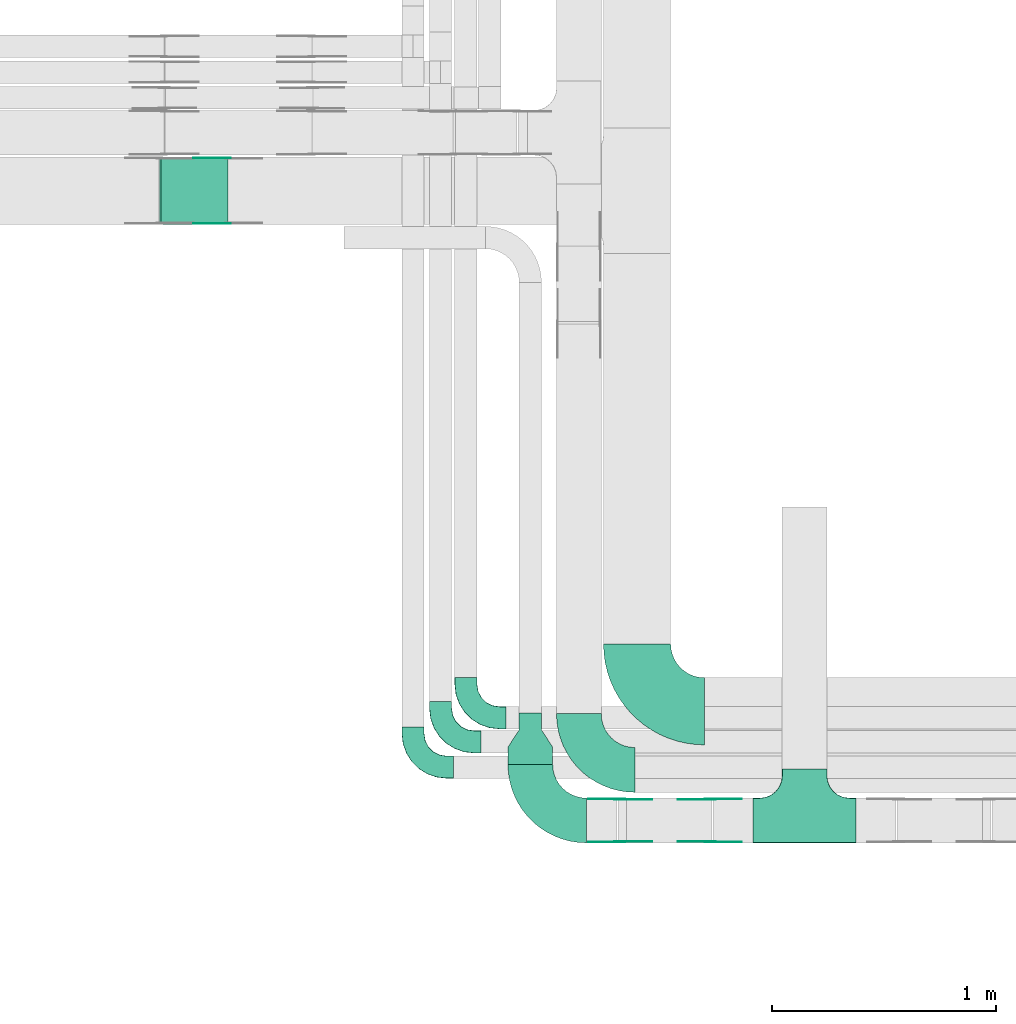
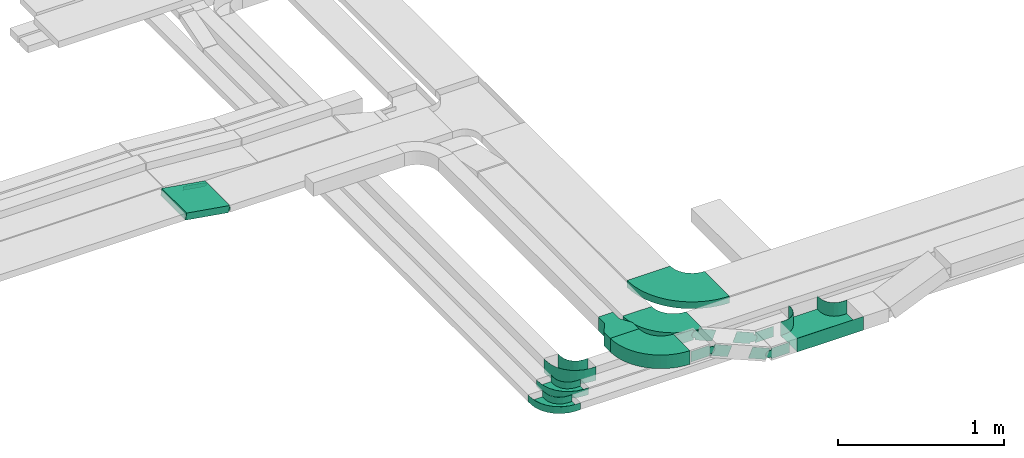
# One storey, part 3 of 19: 18 flow fittings, 1 flow segment.
"""IFC2X3 building model written with IfcOpenShell, lengths in millimetres."""

import ifcopenshell
import ifcopenshell.guid

model = None  # the IFC model being written
_history = None  # IfcOwnerHistory: only IFC2X3 demands one
_inside = {}  # id of a spatial element -> (the spatial element, [elements in it])
_under = {}  # id of a project, library or spatial element -> (it, [spatial elements below it])
_declared = {}  # id of a project -> (the project, [libraries it declares])
_typed = {}  # id of a type object -> (the type object, [elements of that type])
_made_of = {}  # id of a material, layer set ... -> (it, [elements and type objects made of it])


def new_model(schema):
    """Start an empty IFC model of exactly this schema.

    Asked for "IFC4X3", IfcOpenShell would pick the latest addendum, in which some entities
    have other attributes; the version numbers below select the first issue.
    IFC2X3 requires an IfcOwnerHistory on every rooted entity: one is made here for all.
    """
    global model, _history
    if schema == "IFC4X3":
        model = ifcopenshell.file(schema_version=(4, 3, 0, 0))
    else:
        model = ifcopenshell.file(schema=schema)
    _inside.clear()
    _under.clear()
    _declared.clear()
    _typed.clear()
    _made_of.clear()
    _history = None
    if model.schema == "IFC2X3":
        org = make("IfcOrganization", Name="unknown")
        user = make(
            "IfcPersonAndOrganization",
            ThePerson=make("IfcPerson", FamilyName="unknown"),
            TheOrganization=org,
        )
        app = make(
            "IfcApplication",
            ApplicationDeveloper=org,
            Version="unknown",
            ApplicationFullName="unknown",
            ApplicationIdentifier="unknown",
        )
        _history = make(
            "IfcOwnerHistory",
            OwningUser=user,
            OwningApplication=app,
            ChangeAction="ADDED",
            CreationDate=0,
        )
    return model


def make(cls, **values):
    """One entity of the class cls with the attributes given. An attribute that is None is left unset."""
    return model.create_entity(
        cls, **{name: value for name, value in values.items() if value is not None}
    )


def entity(cls, *values):
    """Any entity or typed value of the class cls, its attributes in the order of the schema. None: left unset."""
    e = model.create_entity(cls)
    for i, value in enumerate(values):
        if value is not None:
            e[i] = value
    return e


def rooted(cls, **values):
    """An entity with a GlobalId (a new one), such as an element, a storey or a relation."""
    return make(cls, GlobalId=ifcopenshell.guid.new(), OwnerHistory=_history, **values)


def si_unit(unit_type, name, prefix=None):
    """IfcSIUnit, for example si_unit("LENGTHUNIT", "METRE", prefix="MILLI")."""
    return make("IfcSIUnit", UnitType=unit_type, Prefix=prefix, Name=name)


def converted_unit(unit_type, name, factor, base, dimensions=None, offset=None):
    """IfcConversionBasedUnit, such as the inch: factor (a typed value) times the base unit."""
    return make(
        "IfcConversionBasedUnit"
        if offset is None
        else "IfcConversionBasedUnitWithOffset",
        ConversionOffset=offset,
        Dimensions=None
        if dimensions is None
        else entity("IfcDimensionalExponents", *dimensions),
        UnitType=unit_type,
        Name=name,
        ConversionFactor=make(
            "IfcMeasureWithUnit", ValueComponent=factor, UnitComponent=base
        ),
    )


def derived_unit(unit_type, elements):
    """IfcDerivedUnit: a product of units, each with its exponent."""
    return make(
        "IfcDerivedUnit",
        Elements=[
            make("IfcDerivedUnitElement", Unit=unit, Exponent=power)
            for unit, power in elements
        ],
        UnitType=unit_type,
    )


def assignment(units):
    """IfcUnitAssignment: the units of a project."""
    return None if units is None else make("IfcUnitAssignment", Units=units)


def point(xyz):
    """IfcCartesianPoint."""
    return None if xyz is None else make("IfcCartesianPoint", Coordinates=xyz)


def direction(xyz):
    """IfcDirection."""
    return None if xyz is None else make("IfcDirection", DirectionRatios=xyz)


def frame(location, z_axis=None, x_axis=None):
    """IfcAxis2Placement3D, a coordinate frame: its origin and axes. An axis left out is left unset."""
    return make(
        "IfcAxis2Placement3D",
        Location=point(location),
        Axis=direction(z_axis),
        RefDirection=direction(x_axis),
    )


def frame_2d(location, x_axis=None):
    """IfcAxis2Placement2D, a coordinate frame in the plane: its origin and x axis."""
    return make(
        "IfcAxis2Placement2D", Location=point(location), RefDirection=direction(x_axis)
    )


def origin():
    """The frame at (0, 0, 0) with its axes left unset."""
    return frame((0.0, 0.0, 0.0))


def origin_2d_with_axis():
    """The frame at (0, 0) in the plane with the x axis (1, 0) written out."""
    return frame_2d((0.0, 0.0), x_axis=(1.0, 0.0))


def place(relative_to, where):
    """IfcLocalPlacement: puts the frame where relative to a parent placement (None: the world)."""
    return make(
        "IfcLocalPlacement", PlacementRelTo=relative_to, RelativePlacement=where
    )


def context(
    kind, dimensions, precision=None, world=None, true_north=None, identifier=None
):
    """IfcGeometricRepresentationContext, for example the 3D "Model" context."""
    return make(
        "IfcGeometricRepresentationContext",
        ContextIdentifier=identifier,
        ContextType=kind,
        CoordinateSpaceDimension=dimensions,
        Precision=precision,
        WorldCoordinateSystem=world,
        TrueNorth=true_north,
    )


def subcontext(parent, identifier, kind, view, scale=None):
    """IfcGeometricRepresentationSubContext, for example "Body" below "Model"."""
    return make(
        "IfcGeometricRepresentationSubContext",
        ContextIdentifier=identifier,
        ContextType=kind,
        ParentContext=parent,
        TargetScale=scale,
        TargetView=view,
    )


def project(units=None, contexts=None):
    """IfcProject with its units and contexts."""
    return rooted(
        "IfcProject",
        Name="project",
        RepresentationContexts=contexts,
        UnitsInContext=assignment(units),
    )


def spatial(cls, under=None, at=None, **own):
    """A site, building, storey or space (cls), placed at a placement, below another one or the project."""
    s = rooted(cls, ObjectPlacement=at, **own)
    if under is not None:
        _under.setdefault(under.id(), (under, []))[1].append(s)
    return s


def polyline(points):
    """IfcPolyline through the points."""
    return make("IfcPolyline", Points=[point(p) for p in points])


def circle_curve(where, radius):
    """IfcCircle in the frame where."""
    return make("IfcCircle", Position=where, Radius=radius)


def parameter(value):
    """IfcParameterValue: where a trimmed curve begins or ends, as a parameter of its basis curve."""
    return model.create_entity("IfcParameterValue", value)


def trimmed(basis, trim1, trim2, sense, master):
    """IfcTrimmedCurve: the piece of a basis curve between two trims."""
    return make(
        "IfcTrimmedCurve",
        BasisCurve=basis,
        Trim1=trim1,
        Trim2=trim2,
        SenseAgreement=sense,
        MasterRepresentation=master,
    )


def segment(curve, same_sense, transition):
    """IfcCompositeCurveSegment."""
    return make(
        "IfcCompositeCurveSegment",
        Transition=transition,
        SameSense=same_sense,
        ParentCurve=curve,
    )


def composite_curve(segments, self_intersect=None):
    """IfcCompositeCurve: segments joined end to end."""
    return make("IfcCompositeCurve", Segments=segments, SelfIntersect=self_intersect)


def profile(cls, at=None, kind="AREA", **sizes):
    """A parametric profile (cls). Its sizes go by their IFC names, for example OverallWidth=200.0."""
    return make(cls, ProfileType=kind, Position=at, **sizes)


def rectangle(**sizes):
    """IfcRectangleProfileDef."""
    return profile("IfcRectangleProfileDef", **sizes)


def outline(outer, holes=None, kind="AREA"):
    """IfcArbitraryClosedProfileDef: a profile drawn as a closed curve; with holes, ...WithVoids."""
    if holes is None:
        return make("IfcArbitraryClosedProfileDef", ProfileType=kind, OuterCurve=outer)
    return make(
        "IfcArbitraryProfileDefWithVoids",
        ProfileType=kind,
        OuterCurve=outer,
        InnerCurves=holes,
    )


def extrude(swept, where, along, depth):
    """IfcExtrudedAreaSolid: the profile swept, set in the frame where, extruded along a direction by depth."""
    return make(
        "IfcExtrudedAreaSolid",
        SweptArea=swept,
        Position=where,
        ExtrudedDirection=direction(along),
        Depth=depth,
    )


def faces_of(points, faces, orient=None, outer=None):
    """IfcFace entities. A face is a list of loops; a loop is a list of indices into points, from 0.

    orient and outer hold one flag for each loop. By default every Orientation is true, the
    first loop of a face is its IfcFaceOuterBound and the others are IfcFaceBound.
    """
    made = []
    for i, loops in enumerate(faces):
        bounds = []
        for j, loop in enumerate(loops):
            is_outer = j == 0 if outer is None else outer[i][j]
            bounds.append(
                make(
                    "IfcFaceOuterBound" if is_outer else "IfcFaceBound",
                    Bound=make("IfcPolyLoop", Polygon=[points[k] for k in loop]),
                    Orientation=True if orient is None else orient[i][j],
                )
            )
        made.append(make("IfcFace", Bounds=bounds))
    return made


def faceted_brep(points, faces, orient=None, outer=None, voids=None):
    """IfcFacetedBrep: a solid bounded by flat faces; with voids (closed shells), ...WithVoids."""
    shared = [point(p) for p in points]
    hull = make("IfcClosedShell", CfsFaces=faces_of(shared, faces, orient, outer))
    if voids is None:
        return make("IfcFacetedBrep", Outer=hull)
    return make(
        "IfcFacetedBrepWithVoids",
        Outer=hull,
        Voids=[
            make(cls, CfsFaces=faces_of(shared, fs, o, b)) for cls, fs, o, b in voids
        ],
    )


def shape(context_of_items, identifier, shape_type, items):
    """IfcShapeRepresentation: the items that make up one representation, for example the "Body"."""
    return make(
        "IfcShapeRepresentation",
        ContextOfItems=context_of_items,
        RepresentationIdentifier=identifier,
        RepresentationType=shape_type,
        Items=items,
    )


def source(mapping_origin, context_of_items, identifier, shape_type, items):
    """IfcRepresentationMap: a shape defined once, which mapped items show again and again."""
    return make(
        "IfcRepresentationMap",
        MappingOrigin=mapping_origin,
        MappedRepresentation=shape(context_of_items, identifier, shape_type, items),
    )


def transform(
    local_origin,
    x_axis=None,
    y_axis=None,
    z_axis=None,
    scale=None,
    scale2=None,
    scale3=None,
    uniform=True,
):
    """IfcCartesianTransformationOperator3D, or its non-uniform kind. x_axis, y_axis, z_axis: its Axis1, 2, 3."""
    if uniform:
        return make(
            "IfcCartesianTransformationOperator3D",
            Axis1=direction(x_axis),
            Axis2=direction(y_axis),
            LocalOrigin=point(local_origin),
            Scale=scale,
            Axis3=direction(z_axis),
        )
    return make(
        "IfcCartesianTransformationOperator3DnonUniform",
        Axis1=direction(x_axis),
        Axis2=direction(y_axis),
        LocalOrigin=point(local_origin),
        Scale=scale,
        Axis3=direction(z_axis),
        Scale2=scale2,
        Scale3=scale3,
    )


def mapped(mapping_source, mapping_target):
    """IfcMappedItem: shows the shape of a source again, moved by a transform."""
    return make(
        "IfcMappedItem", MappingSource=mapping_source, MappingTarget=mapping_target
    )


def material(Name=None, Category=None):
    """IfcMaterial."""
    return make("IfcMaterial", Name=Name, Category=Category)


def made_of(thing, what):
    """Note that an element or type object is made of a material, layer set ...; save() writes the relation."""
    if what is not None:
        _made_of.setdefault(what.id(), (what, []))[1].append(thing)
    return thing


def type_object(cls, material=None, **own):
    """A type object (cls), such as IfcWallType, which elements share."""
    return made_of(rooted(cls, **own), material)


def type_shapes(of_type, sources):
    """Give a type object the sources (RepresentationMaps) that its elements show as mapped items."""
    of_type.RepresentationMaps = sources


def element(
    cls,
    number,
    at=None,
    inside=None,
    cuts=None,
    type_object=None,
    material=None,
    context=None,
    identifier="Body",
    shape_type=None,
    held_by="IfcProductDefinitionShape",
    body=None,
    shapes=None,
    **own,
):
    """One element of the class cls, such as IfcWall. Its Tag is "e" and its number.

    at: its placement. inside: the storey or other place that contains it. cuts: it is an
    opening in that element (IfcRelVoidsElement). A single representation is given by context,
    identifier, shape_type and body (its items); several are given by shapes. held_by: the class
    of the entity that holds the representations. save() writes the other relations.
    """
    e = rooted(cls, Tag="e%d" % number, ObjectPlacement=at, **own)
    if body is not None:
        shapes = [shape(context, identifier, shape_type, body)]
    if shapes is not None:
        e.Representation = make(held_by, Representations=shapes)
    if inside is not None:
        _inside.setdefault(inside.id(), (inside, []))[1].append(e)
    if cuts is not None:
        rooted(
            "IfcRelVoidsElement", RelatingBuildingElement=cuts, RelatedOpeningElement=e
        )
    if type_object is not None:
        _typed.setdefault(type_object.id(), (type_object, []))[1].append(e)
    return made_of(e, material)


def aggregate(whole, parts):
    """IfcRelAggregates: a whole, such as a stair, and the parts it consists of."""
    return rooted("IfcRelAggregates", RelatingObject=whole, RelatedObjects=parts)


def save(model, path):
    """Write the relations noted so far, then the file.

    IfcRelAggregates (storeys below a building ...), IfcRelContainedInSpatialStructure (elements
    in a storey), IfcRelDefinesByType, IfcRelAssociatesMaterial and IfcRelDeclares: one each for
    every whole, place, type object, material and project.
    """
    for whole, parts in _under.values():
        aggregate(whole, parts)
    for where, things in _inside.values():
        rooted(
            "IfcRelContainedInSpatialStructure",
            RelatedElements=things,
            RelatingStructure=where,
        )
    for kind, things in _typed.values():
        rooted("IfcRelDefinesByType", RelatedObjects=things, RelatingType=kind)
    for what, things in _made_of.values():
        rooted("IfcRelAssociatesMaterial", RelatedObjects=things, RelatingMaterial=what)
    for by, libraries in _declared.values():
        rooted("IfcRelDeclares", RelatingContext=by, RelatedDefinitions=libraries)
    model.write(path)


model = new_model("IFC2X3")

# Units and contexts
model_context = context("Model", 3, precision=0.01, world=origin(), true_north=direction((6.12303176911189e-17, 1.0)))
body_context = subcontext(model_context, "Body", "Model", "MODEL_VIEW")
ifc_project = project(units=[si_unit("LENGTHUNIT", "METRE", prefix="MILLI"), si_unit("AREAUNIT", "SQUARE_METRE"), si_unit("VOLUMEUNIT", "CUBIC_METRE"), converted_unit("PLANEANGLEUNIT", "DEGREE", entity("IfcRatioMeasure", 0.0174532925199433), si_unit("PLANEANGLEUNIT", "RADIAN"), dimensions=[0, 0, 0, 0, 0, 0, 0]), si_unit("MASSUNIT", "GRAM", prefix="KILO"), derived_unit("MASSDENSITYUNIT", [(si_unit("MASSUNIT", "GRAM", prefix="KILO"), 1), (si_unit("LENGTHUNIT", "METRE"), -3)]), derived_unit("MOMENTOFINERTIAUNIT", [(si_unit("LENGTHUNIT", "METRE"), 4)]), si_unit("TIMEUNIT", "SECOND"), si_unit("FREQUENCYUNIT", "HERTZ"), si_unit("THERMODYNAMICTEMPERATUREUNIT", "DEGREE_CELSIUS"), derived_unit("THERMALTRANSMITTANCEUNIT", [(si_unit("MASSUNIT", "GRAM", prefix="KILO"), 1), (si_unit("THERMODYNAMICTEMPERATUREUNIT", "KELVIN"), -1), (si_unit("TIMEUNIT", "SECOND"), -3)]), derived_unit("VOLUMETRICFLOWRATEUNIT", [(si_unit("LENGTHUNIT", "METRE"), 3), (si_unit("TIMEUNIT", "SECOND"), -1)]), derived_unit("MASSFLOWRATEUNIT", [(si_unit("MASSUNIT", "GRAM", prefix="KILO"), 1), (si_unit("TIMEUNIT", "SECOND"), -1)]), derived_unit("ROTATIONALFREQUENCYUNIT", [(si_unit("TIMEUNIT", "SECOND"), -1)]), si_unit("ELECTRICCURRENTUNIT", "AMPERE"), si_unit("ELECTRICVOLTAGEUNIT", "VOLT"), si_unit("POWERUNIT", "WATT"), si_unit("FORCEUNIT", "NEWTON", prefix="KILO"), si_unit("ILLUMINANCEUNIT", "LUX"), si_unit("LUMINOUSFLUXUNIT", "LUMEN"), si_unit("LUMINOUSINTENSITYUNIT", "CANDELA"), derived_unit("USERDEFINED", [(si_unit("MASSUNIT", "GRAM", prefix="KILO"), -1), (si_unit("LENGTHUNIT", "METRE"), -2), (si_unit("TIMEUNIT", "SECOND"), 3), (si_unit("LUMINOUSFLUXUNIT", "LUMEN"), 1)]), derived_unit("LINEARVELOCITYUNIT", [(si_unit("LENGTHUNIT", "METRE"), 1), (si_unit("TIMEUNIT", "SECOND"), -1)]), si_unit("PRESSUREUNIT", "PASCAL"), derived_unit("USERDEFINED", [(si_unit("LENGTHUNIT", "METRE"), -2), (si_unit("MASSUNIT", "GRAM", prefix="KILO"), 1), (si_unit("TIMEUNIT", "SECOND"), -2)]), derived_unit("LINEARFORCEUNIT", [(si_unit("MASSUNIT", "GRAM", prefix="KILO"), 1), (si_unit("LENGTHUNIT", "METRE"), 1), (si_unit("TIMEUNIT", "SECOND"), -2), (si_unit("LENGTHUNIT", "METRE"), -1)]), derived_unit("PLANARFORCEUNIT", [(si_unit("MASSUNIT", "GRAM", prefix="KILO"), 1), (si_unit("LENGTHUNIT", "METRE"), 1), (si_unit("TIMEUNIT", "SECOND"), -2), (si_unit("LENGTHUNIT", "METRE"), -2)])], contexts=[model_context])

# Site, building, storey
site_placement = place(None, origin())
site = spatial("IfcSite", under=ifc_project, at=site_placement, CompositionType="ELEMENT")
building_placement = place(site_placement, origin())
building = spatial("IfcBuilding", under=site, at=building_placement, CompositionType="ELEMENT")
storey_placement = place(building_placement, frame((0.0, 0.0, 12000.0)))
storey = spatial("IfcBuildingStorey", under=building, at=storey_placement, CompositionType="ELEMENT", Elevation=12000.0)

# Flow segment
cable_carrier_segment_type = type_object("IfcCableCarrierSegmentType", PredefinedType="CABLETRAYSEGMENT")
flow_segment_placement = place(storey_placement, frame((16244.96, 12249.79, 2800.87)))
element("IfcFlowSegment", 1, at=flow_segment_placement, inside=storey, type_object=cable_carrier_segment_type, context=body_context, shape_type="SweptSolid", body=[
    extrude(rectangle(XDim=50.0000000000021, YDim=300.000000000001, at=origin_2d_with_axis()), frame((4.04, 150.0, 73.59), z_axis=(0.986849163973504, 0.0, -0.161643829343391), x_axis=(0.161643829343391, 0.0, 0.986849163973504)), (0.0, 0.0, 1.0), 302.603347436749),
])

# Flow fittings
ifc_material_1 = material()
cable_carrier_fitting_type_1 = type_object("IfcCableCarrierFittingType", PredefinedType="NOTDEFINED", material=ifc_material_1)
shared_shape_1 = source(origin(), body_context, "Body", "SweptSolid", [
    extrude(outline(polyline([(-115.0, -100.0), (-38.33, -100.0), (38.33, -50.0), (115.0, -50.0), (115.0, 50.0), (38.33, 50.0), (-38.33, 100.0), (-115.0, 100.0), (-115.0, -100.0)])), frame((115.0, 0.0, -50.0)), (0.0, 0.0, 1.0), 100.0),
])
type_shapes(cable_carrier_fitting_type_1, [shared_shape_1])
flow_fitting_1_placement = place(storey_placement, frame((17901.67, 9838.45, 2850.0), z_axis=(0.0, 0.0, 1.0), x_axis=(0.0, 1.0, 0.0)))
element("IfcFlowFitting", 2, at=flow_fitting_1_placement, inside=storey, type_object=cable_carrier_fitting_type_1, material=ifc_material_1, Name="470_DKC_S5_adapter", context=body_context, shape_type="MappedRepresentation", body=[
    mapped(shared_shape_1, transform((0.0, 0.0, 0.0), scale=1.0)),
])
cable_carrier_fitting_type_2 = type_object("IfcCableCarrierFittingType", PredefinedType="NOTDEFINED", material=ifc_material_1)
shared_shape_2 = source(origin(), body_context, "Body", "Brep", [
    faceted_brep([(-103.41, -174.12, 50.0), (-100.0, -200.0, 50.0), (-100.0, -230.0, 50.0), (-99.2, -230.0, 50.0), (-99.2, -200.0, 50.0), (-102.63, -173.91, 50.0), (-112.7, -149.6, 50.0), (-128.72, -128.72, 50.0), (-149.6, -112.7, 50.0), (-173.91, -102.63, 50.0), (-200.0, -99.2, 50.0), (-230.0, -99.2, 50.0), (-230.0, -100.0, 50.0), (-200.0, -100.0, 50.0), (-174.12, -103.41, 50.0), (-150.0, -113.4, 50.0), (-129.29, -129.29, 50.0), (-113.4, -150.0, 50.0), (230.0, -100.0, 50.0), (230.0, -99.2, 50.0), (200.0, -99.2, 50.0), (173.91, -102.63, 50.0), (149.6, -112.7, 50.0), (128.72, -128.72, 50.0), (112.7, -149.6, 50.0), (102.63, -173.91, 50.0), (99.2, -200.0, 50.0), (99.2, -230.0, 50.0), (100.0, -230.0, 50.0), (100.0, -200.0, 50.0), (103.41, -174.12, 50.0), (113.4, -150.0, 50.0), (129.29, -129.29, 50.0), (150.0, -113.4, 50.0), (174.12, -103.41, 50.0), (200.0, -100.0, 50.0), (230.0, 99.2, 50.0), (230.0, 100.0, 50.0), (-230.0, 100.0, 50.0), (-230.0, 99.2, 50.0), (-230.0, -100.0, -50.0), (-230.0, 100.0, -50.0), (230.0, 100.0, -50.0), (230.0, -100.0, -50.0), (200.0, -100.0, -50.0), (174.12, -103.41, -50.0), (150.0, -113.4, -50.0), (129.29, -129.29, -50.0), (113.4, -150.0, -50.0), (103.41, -174.12, -50.0), (100.0, -200.0, -50.0), (100.0, -230.0, -50.0), (-100.0, -230.0, -50.0), (-100.0, -200.0, -50.0), (-103.41, -174.12, -50.0), (-113.4, -150.0, -50.0), (-129.29, -129.29, -50.0), (-150.0, -113.4, -50.0), (-174.12, -103.41, -50.0), (-200.0, -100.0, -50.0), (-100.0, -200.0, -49.2), (99.2, -230.0, -49.2), (-99.2, -230.0, -49.2), (-99.2, -200.0, -49.2), (-200.0, -99.2, -49.2), (-230.0, -99.2, -49.2), (230.0, -99.2, -49.2), (200.0, -99.2, -49.2), (-230.0, 99.2, -49.2), (-200.0, -100.0, -49.2), (200.0, -100.0, -49.2), (230.0, 99.2, -49.2), (99.2, -200.0, -49.2), (100.0, -200.0, -49.2), (-173.91, -102.63, -49.2), (-149.6, -112.7, -49.2), (-128.72, -128.72, -49.2), (-112.7, -149.6, -49.2), (-102.63, -173.91, -49.2), (102.63, -173.91, -49.2), (112.7, -149.6, -49.2), (128.72, -128.72, -49.2), (149.6, -112.7, -49.2), (173.91, -102.63, -49.2)], [[[0, 1, 2, 3, 4, 5, 6, 7, 8, 9, 10, 11, 12, 13, 14, 15, 16, 17]], [[18, 19, 20, 21, 22, 23, 24, 25, 26, 27, 28, 29, 30, 31, 32, 33, 34, 35]], [[36, 37, 38, 39]], [[40, 41, 42, 43, 44, 45, 46, 47, 48, 49, 50, 51, 52, 53, 54, 55, 56, 57, 58, 59]], [[2, 1, 60, 53, 52]], [[3, 2, 52, 51, 28, 27, 61, 62]], [[4, 3, 62, 63]], [[11, 10, 64, 65]], [[20, 19, 66, 67]], [[39, 38, 41, 40, 12, 11, 65, 68]], [[13, 12, 40, 59, 69]], [[18, 35, 70, 44, 43]], [[19, 18, 43, 42, 37, 36, 71, 66]], [[27, 26, 72, 61]], [[29, 28, 51, 50, 73]], [[38, 37, 42, 41]], [[36, 39, 68, 71]], [[68, 65, 64, 74, 75, 76, 77, 78, 63, 62, 61, 72, 79, 80, 81, 82, 83, 67, 66, 71]], [[14, 13, 69, 59, 58]], [[15, 14, 58, 57]], [[57, 56, 16, 15]], [[17, 16, 56, 55]], [[0, 17, 55, 54]], [[1, 0, 54, 53, 60]], [[5, 78, 77, 6]], [[6, 77, 76, 7]], [[63, 78, 5, 4]], [[8, 75, 74, 9]], [[9, 74, 64, 10]], [[7, 76, 75, 8]], [[21, 83, 82, 22]], [[22, 82, 81, 23]], [[67, 83, 21, 20]], [[24, 80, 79, 25]], [[25, 79, 72, 26]], [[23, 81, 80, 24]], [[30, 29, 73, 50, 49]], [[31, 30, 49, 48]], [[32, 31, 48, 47]], [[34, 33, 46, 45]], [[34, 45, 44, 70, 35]], [[46, 33, 32, 47]]]),
])
type_shapes(cable_carrier_fitting_type_2, [shared_shape_2])
flow_fitting_2_placement = place(storey_placement, frame((19126.52, 9587.45, 2678.65), z_axis=(0.0, 0.0, 1.0), x_axis=(-1.0, 0.0, 0.0)))
element("IfcFlowFitting", 3, at=flow_fitting_2_placement, inside=storey, type_object=cable_carrier_fitting_type_2, material=ifc_material_1, Name="470_DKC_S5_T", context=body_context, shape_type="MappedRepresentation", body=[
    mapped(shared_shape_2, transform((0.0, 0.0, 0.0), scale=1.0)),
])
cable_carrier_fitting_type_3 = type_object("IfcCableCarrierFittingType", Name="470_DKC_S5_CPO 45 horizontal angle:-", PredefinedType="NOTDEFINED", material=ifc_material_1)
shared_shape_3 = source(origin(), body_context, "Body", "Brep", [
    faceted_brep([(-180.0, -49.2, -49.2), (-180.0, 49.2, -49.2), (-180.0, 49.2, 50.0), (-180.0, 50.0, 50.0), (-180.0, 50.0, -50.0), (-180.0, -50.0, -50.0), (-180.0, -50.0, 50.0), (-180.0, -49.2, 50.0), (-150.0, -50.0, -50.0), (-150.0, -50.0, 50.0), (-105.5, -44.99, 50.0), (-63.22, -30.19, 50.0), (-25.3, -6.37, 50.0), (6.37, 25.3, 50.0), (30.19, 63.22, 50.0), (44.99, 105.5, 50.0), (50.0, 150.0, 50.0), (50.0, 180.0, 50.0), (49.2, 180.0, 50.0), (49.2, 150.0, 50.0), (44.21, 105.67, 50.0), (29.47, 63.57, 50.0), (5.74, 25.8, 50.0), (-25.8, -5.74, 50.0), (-63.57, -29.47, 50.0), (-105.67, -44.21, 50.0), (-150.0, -49.2, 50.0), (-150.0, 49.2, 50.0), (-118.85, 54.13, 50.0), (-90.75, 68.45, 50.0), (-68.45, 90.75, 50.0), (-54.13, 118.85, 50.0), (-49.2, 150.0, 50.0), (-49.2, 180.0, 50.0), (-50.0, 180.0, 50.0), (-50.0, 150.0, 50.0), (-54.89, 119.1, 50.0), (-69.1, 91.22, 50.0), (-91.22, 69.1, 50.0), (-119.1, 54.89, 50.0), (-150.0, 50.0, 50.0), (-150.0, -49.2, -49.2), (-105.67, -44.21, -49.2), (-63.57, -29.47, -49.2), (-25.8, -5.74, -49.2), (5.74, 25.8, -49.2), (29.47, 63.57, -49.2), (44.21, 105.67, -49.2), (49.2, 150.0, -49.2), (49.2, 180.0, -49.2), (-49.2, 180.0, -49.2), (-49.2, 150.0, -49.2), (-54.13, 118.85, -49.2), (-68.45, 90.75, -49.2), (-90.75, 68.45, -49.2), (-118.85, 54.13, -49.2), (-150.0, 49.2, -49.2), (-150.0, 50.0, -50.0), (-119.1, 54.89, -50.0), (-91.22, 69.1, -50.0), (-69.1, 91.22, -50.0), (-54.89, 119.1, -50.0), (-50.0, 150.0, -50.0), (-50.0, 180.0, -50.0), (50.0, 180.0, -50.0), (50.0, 150.0, -50.0), (44.99, 105.5, -50.0), (30.19, 63.22, -50.0), (6.37, 25.3, -50.0), (-25.3, -6.37, -50.0), (-63.22, -30.19, -50.0), (-105.5, -44.99, -50.0)], [[[0, 1, 2, 3, 4, 5, 6, 7]], [[6, 5, 8, 9]], [[7, 6, 9, 10, 11, 12, 13, 14, 15, 16, 17, 18, 19, 20, 21, 22, 23, 24, 25, 26]], [[3, 2, 27, 28, 29, 30, 31, 32, 33, 34, 35, 36, 37, 38, 39, 40]], [[0, 7, 26, 41]], [[1, 0, 41, 42, 43, 44, 45, 46, 47, 48, 49, 50, 51, 52, 53, 54, 55, 56]], [[2, 1, 56, 27]], [[4, 3, 40, 57]], [[57, 58, 59, 60, 61, 62, 63, 64, 65, 66, 67, 68, 69, 70, 71, 8, 5, 4]], [[10, 9, 8, 71]], [[71, 70, 11, 10]], [[69, 12, 11, 70]], [[69, 68, 13, 12]], [[13, 68, 67, 14]], [[14, 67, 66, 15]], [[15, 66, 65, 16]], [[42, 41, 26, 25]], [[24, 43, 42, 25]], [[43, 24, 23, 44]], [[23, 22, 45, 44]], [[46, 45, 22, 21]], [[47, 46, 21, 20]], [[48, 47, 20, 19]], [[55, 54, 29, 28]], [[56, 55, 28, 27]], [[54, 53, 30, 29]], [[30, 53, 52, 31]], [[31, 52, 51, 32]], [[39, 38, 59, 58]], [[39, 58, 57, 40]], [[38, 37, 60, 59]], [[61, 60, 37, 36]], [[62, 61, 36, 35]], [[63, 34, 33, 50, 49, 18, 17, 64]], [[16, 65, 64, 17]], [[48, 19, 18, 49]], [[32, 51, 50, 33]], [[62, 35, 34, 63]]]),
])
type_shapes(cable_carrier_fitting_type_3, [shared_shape_3])
flow_fitting_3_placement = place(storey_placement, frame((17613.86, 10046.0, 2550.0), z_axis=(0.0, -0.000495218494767808, 0.999999877379314), x_axis=(0.0, -0.999999877379314, -0.000495218494767808)))
element("IfcFlowFitting", 4, at=flow_fitting_3_placement, inside=storey, type_object=cable_carrier_fitting_type_3, material=ifc_material_1, Name="470_DKC_S5_45 horizontal angle", ObjectType="470_DKC_S5_CPO 45 horizontal angle:-", context=body_context, shape_type="MappedRepresentation", body=[
    mapped(shared_shape_3, transform((0.0, 0.0, 0.0), scale=1.0)),
])
cable_carrier_fitting_type_4 = type_object("IfcCableCarrierFittingType", Name="470_DKC_S5_CPO 45 horizontal angle:-", PredefinedType="NOTDEFINED", material=ifc_material_1)
shared_shape_4 = source(origin(), body_context, "Body", "Brep", [
    faceted_brep([(-180.0, -49.2, -24.2), (-180.0, 49.2, -24.2), (-180.0, 49.2, 25.0), (-180.0, 50.0, 25.0), (-180.0, 50.0, -25.0), (-180.0, -50.0, -25.0), (-180.0, -50.0, 25.0), (-180.0, -49.2, 25.0), (-150.0, -50.0, -25.0), (-150.0, -50.0, 25.0), (-105.5, -44.99, 25.0), (-63.22, -30.19, 25.0), (-25.3, -6.37, 25.0), (6.37, 25.3, 25.0), (30.19, 63.22, 25.0), (44.99, 105.5, 25.0), (50.0, 150.0, 25.0), (50.0, 180.0, 25.0), (49.2, 180.0, 25.0), (49.2, 150.0, 25.0), (44.21, 105.67, 25.0), (29.47, 63.57, 25.0), (5.74, 25.8, 25.0), (-25.8, -5.74, 25.0), (-63.57, -29.47, 25.0), (-105.67, -44.21, 25.0), (-150.0, -49.2, 25.0), (-150.0, 49.2, 25.0), (-118.85, 54.13, 25.0), (-90.75, 68.45, 25.0), (-68.45, 90.75, 25.0), (-54.13, 118.85, 25.0), (-49.2, 150.0, 25.0), (-49.2, 180.0, 25.0), (-50.0, 180.0, 25.0), (-50.0, 150.0, 25.0), (-54.89, 119.1, 25.0), (-69.1, 91.22, 25.0), (-91.22, 69.1, 25.0), (-119.1, 54.89, 25.0), (-150.0, 50.0, 25.0), (-150.0, -49.2, -24.2), (-105.67, -44.21, -24.2), (-63.57, -29.47, -24.2), (-25.8, -5.74, -24.2), (5.74, 25.8, -24.2), (29.47, 63.57, -24.2), (44.21, 105.67, -24.2), (49.2, 150.0, -24.2), (49.2, 180.0, -24.2), (-49.2, 180.0, -24.2), (-49.2, 150.0, -24.2), (-54.13, 118.85, -24.2), (-68.45, 90.75, -24.2), (-90.75, 68.45, -24.2), (-118.85, 54.13, -24.2), (-150.0, 49.2, -24.2), (-150.0, 50.0, -25.0), (-119.1, 54.89, -25.0), (-91.22, 69.1, -25.0), (-69.1, 91.22, -25.0), (-54.89, 119.1, -25.0), (-50.0, 150.0, -25.0), (-50.0, 180.0, -25.0), (50.0, 180.0, -25.0), (50.0, 150.0, -25.0), (44.99, 105.5, -25.0), (30.19, 63.22, -25.0), (6.37, 25.3, -25.0), (-25.3, -6.37, -25.0), (-63.22, -30.19, -25.0), (-105.5, -44.99, -25.0)], [[[0, 1, 2, 3, 4, 5, 6, 7]], [[6, 5, 8, 9]], [[7, 6, 9, 10, 11, 12, 13, 14, 15, 16, 17, 18, 19, 20, 21, 22, 23, 24, 25, 26]], [[3, 2, 27, 28, 29, 30, 31, 32, 33, 34, 35, 36, 37, 38, 39, 40]], [[0, 7, 26, 41]], [[1, 0, 41, 42, 43, 44, 45, 46, 47, 48, 49, 50, 51, 52, 53, 54, 55, 56]], [[2, 1, 56, 27]], [[4, 3, 40, 57]], [[57, 58, 59, 60, 61, 62, 63, 64, 65, 66, 67, 68, 69, 70, 71, 8, 5, 4]], [[10, 9, 8, 71]], [[71, 70, 11, 10]], [[69, 12, 11, 70]], [[69, 68, 13, 12]], [[68, 67, 14, 13]], [[67, 66, 15, 14]], [[15, 66, 65, 16]], [[42, 41, 26, 25]], [[24, 43, 42, 25]], [[43, 24, 23, 44]], [[23, 22, 45, 44]], [[21, 46, 45, 22]], [[21, 20, 47, 46]], [[48, 47, 20, 19]], [[28, 27, 56, 55]], [[29, 28, 55, 54]], [[54, 53, 30, 29]], [[31, 30, 53, 52]], [[31, 52, 51, 32]], [[58, 57, 40, 39]], [[59, 58, 39, 38]], [[38, 37, 60, 59]], [[61, 60, 37, 36]], [[62, 61, 36, 35]], [[63, 34, 33, 50, 49, 18, 17, 64]], [[16, 65, 64, 17]], [[48, 19, 18, 49]], [[32, 51, 50, 33]], [[62, 35, 34, 63]]]),
])
type_shapes(cable_carrier_fitting_type_4, [shared_shape_4])
for number, where, z_axis, x_axis, name in (
    (5, (17377.76, 9825.5, 2525.0), (0.0, 0.0, 1.0), (0.0, -1.0, 0.0), "470_DKC_S5_45 horizontal angle"),
    (6, (17500.8, 9938.36, 2525.0), (0.0, 0.0, 1.0), (0.0, -1.0, 0.0), "470_DKC_S5_45 horizontal angle"),
):
    element("IfcFlowFitting", number, at=place(storey_placement, frame(where, z_axis=z_axis, x_axis=x_axis)), inside=storey, type_object=cable_carrier_fitting_type_4, material=ifc_material_1, Name=name, ObjectType="470_DKC_S5_CPO 45 horizontal angle:-", context=body_context, shape_type="MappedRepresentation", body=[
        mapped(shared_shape_4, transform((0.0, 0.0, 0.0), scale=1.0)),
    ])
cable_carrier_fitting_type_5 = type_object("IfcCableCarrierFittingType", Name="470_DKC_S5_Variable Angle Elbow 0-45:-", PredefinedType="NOTDEFINED", material=ifc_material_1)
shared_shape_5 = source(origin(), body_context, "Body", "SweptSolid", [
    extrude(outline(composite_curve([segment(polyline([(-150.75, -300.25), (-149.75, -300.25)]), True, "CONTINUOUS"), segment(trimmed(circle_curve(frame_2d((-149.75, 149.75), x_axis=(0.0, -1.0)), 450.0), [parameter(0.0)], [parameter(90.0000000000001)], True, "PARAMETER"), True, "CONTINUOUS"), segment(polyline([(300.25, 149.75), (300.25, 150.75)]), True, "CONTINUOUS"), segment(polyline([(300.25, 150.75), (0.25, 150.75)]), True, "CONTINUOUS"), segment(polyline([(0.25, 150.75), (0.25, 149.75)]), True, "CONTINUOUS"), segment(trimmed(circle_curve(frame_2d((-149.75, 149.75), x_axis=(0.0, -1.0)), 150.0), [parameter(0.0)], [parameter(90.0000000000001)], True, "PARAMETER"), False, "CONTINUOUS"), segment(polyline([(-149.75, -0.25), (-150.75, -0.25)]), True, "CONTINUOUS"), segment(polyline([(-150.75, -0.25), (-150.75, -300.25)]), True, "CONTINUOUS")], self_intersect=False)), frame((-150.25, 150.25, -25.0)), (0.0, 0.0, 1.0), 49.9999999999974),
])
type_shapes(cable_carrier_fitting_type_5, [shared_shape_5])
flow_fitting_4_placement = place(storey_placement, frame((18378.54, 10074.94, 2825.0), z_axis=(0.0, 0.0, 1.0), x_axis=(0.0, -1.0, 0.0)))
element("IfcFlowFitting", 7, at=flow_fitting_4_placement, inside=storey, type_object=cable_carrier_fitting_type_5, material=ifc_material_1, Name="470_DKC_S5_Variable Angle Elbow 0-45:-", ObjectType="470_DKC_S5_Variable Angle Elbow 0-45:-", context=body_context, shape_type="MappedRepresentation", body=[
    mapped(shared_shape_5, transform((0.0, 0.0, 0.0), scale=1.0)),
])
cable_carrier_fitting_type_6 = type_object("IfcCableCarrierFittingType", Name="470_DKC_S5_Variable Angle Elbow 0-45:-", PredefinedType="NOTDEFINED", material=ifc_material_1)
shared_shape_6 = source(origin(), body_context, "Body", "SweptSolid", [
    extrude(outline(composite_curve([segment(polyline([(-125.75, -225.25), (-124.75, -225.25)]), True, "CONTINUOUS"), segment(trimmed(circle_curve(frame_2d((-124.75, 124.75), x_axis=(0.0, -1.0)), 350.0), [parameter(0.0)], [parameter(90.0000000000001)], True, "PARAMETER"), True, "CONTINUOUS"), segment(polyline([(225.25, 124.75), (225.25, 125.75)]), True, "CONTINUOUS"), segment(polyline([(225.25, 125.75), (25.25, 125.75)]), True, "CONTINUOUS"), segment(polyline([(25.25, 125.75), (25.25, 124.75)]), True, "CONTINUOUS"), segment(trimmed(circle_curve(frame_2d((-124.75, 124.75), x_axis=(0.0, -1.0)), 150.0), [parameter(0.0)], [parameter(90.0000000000001)], True, "PARAMETER"), False, "CONTINUOUS"), segment(polyline([(-124.75, -25.25), (-125.75, -25.25)]), True, "CONTINUOUS"), segment(polyline([(-125.75, -25.25), (-125.75, -225.25)]), True, "CONTINUOUS")], self_intersect=False)), frame((-125.25, 125.25, -50.0)), (0.0, 0.0, 1.0), 100.0),
])
type_shapes(cable_carrier_fitting_type_6, [shared_shape_6])
flow_fitting_5_placement = place(storey_placement, frame((17901.67, 9587.45, 2850.0), z_axis=(0.0, 0.0, 1.0), x_axis=(0.0, -1.0, 0.0)))
element("IfcFlowFitting", 8, at=flow_fitting_5_placement, inside=storey, type_object=cable_carrier_fitting_type_6, material=ifc_material_1, Name="470_DKC_S5_Variable Angle Elbow 0-45:-", ObjectType="470_DKC_S5_Variable Angle Elbow 0-45:-", context=body_context, shape_type="MappedRepresentation", body=[
    mapped(shared_shape_6, transform((0.0, 0.0, 0.0), scale=1.0)),
])
ifc_material_2 = material(Name="G")
cable_carrier_fitting_type_7 = type_object("IfcCableCarrierFittingType", PredefinedType="NOTDEFINED", material=ifc_material_2)
shared_shape_7 = source(origin(), body_context, "Body", "SweptSolid", [
    extrude(outline(composite_curve([segment(trimmed(circle_curve(frame_2d((-44.59, 0.0), x_axis=(1.0, 0.0)), 12.5), [parameter(90.0000000000007)], [parameter(270.0)], True, "PARAMETER"), True, "CONTINUOUS"), segment(polyline([(-44.59, -12.5), (-33.09, -12.5)]), True, "CONTINUOUS"), segment(polyline([(-33.09, -12.5), (-31.23, -14.5)]), True, "CONTINUOUS"), segment(polyline([(-31.23, -14.5), (108.91, -14.5)]), True, "CONTINUOUS"), segment(polyline([(108.91, -14.5), (108.91, 14.5)]), True, "CONTINUOUS"), segment(polyline([(108.91, 14.5), (-31.23, 14.5)]), True, "CONTINUOUS"), segment(polyline([(-31.23, 14.5), (-33.09, 12.5)]), True, "CONTINUOUS"), segment(polyline([(-33.09, 12.5), (-44.59, 12.5)]), True, "CONTINUOUS")], self_intersect=False)), frame((44.59, 0.0, 0.0), z_axis=(0.0, 0.0, -1.0), x_axis=(1.0, 0.0, 0.0)), (0.0, 0.0, -1.0), 2.0),
])
type_shapes(cable_carrier_fitting_type_7, [shared_shape_7])
flow_fitting_6_placement = place(storey_placement, frame((16550.94, 12545.25, 2825.0), z_axis=(0.0, 1.0, 0.0), x_axis=(-0.986849163973513, 0.0, 0.161643829343339)))
element("IfcFlowFitting", 9, at=flow_fitting_6_placement, inside=storey, type_object=cable_carrier_fitting_type_7, material=ifc_material_2, context=body_context, shape_type="MappedRepresentation", body=[
    mapped(shared_shape_7, transform((0.0, 0.0, 0.0), scale=1.0)),
])
cable_carrier_fitting_type_8 = type_object("IfcCableCarrierFittingType", PredefinedType="NOTDEFINED", material=ifc_material_2)
shared_shape_8 = source(origin(), body_context, "Body", "SweptSolid", [
    extrude(outline(composite_curve([segment(trimmed(circle_curve(frame_2d((-44.59, 0.0), x_axis=(1.0, 0.0)), 12.5), [parameter(90.0000000000007)], [parameter(270.0)], True, "PARAMETER"), True, "CONTINUOUS"), segment(polyline([(-44.59, -12.5), (-33.09, -12.5)]), True, "CONTINUOUS"), segment(polyline([(-33.09, -12.5), (-31.23, -14.5)]), True, "CONTINUOUS"), segment(polyline([(-31.23, -14.5), (108.91, -14.5)]), True, "CONTINUOUS"), segment(polyline([(108.91, -14.5), (108.91, 14.5)]), True, "CONTINUOUS"), segment(polyline([(108.91, 14.5), (-31.23, 14.5)]), True, "CONTINUOUS"), segment(polyline([(-31.23, 14.5), (-33.09, 12.5)]), True, "CONTINUOUS"), segment(polyline([(-33.09, 12.5), (-44.59, 12.5)]), True, "CONTINUOUS")], self_intersect=False)), frame((44.59, 0.0, 0.0)), (0.0, 0.0, 1.0), 2.0),
])
type_shapes(cable_carrier_fitting_type_8, [shared_shape_8])
flow_fitting_7_placement = place(storey_placement, frame((16550.94, 12254.33, 2825.0), z_axis=(0.0, -1.0, 0.0), x_axis=(-0.986849163973513, 0.0, 0.161643829343339)))
element("IfcFlowFitting", 10, at=flow_fitting_7_placement, inside=storey, type_object=cable_carrier_fitting_type_8, material=ifc_material_2, context=body_context, shape_type="MappedRepresentation", body=[
    mapped(shared_shape_8, transform((0.0, 0.0, 0.0), scale=1.0)),
])
cable_carrier_fitting_type_9 = type_object("IfcCableCarrierFittingType", Name="470_DKC_S5_Variable Angle Elbow 0-45:-", PredefinedType="NOTDEFINED", material=ifc_material_1)
shared_shape_9 = source(origin(), body_context, "Body", "SweptSolid", [
    extrude(outline(composite_curve([segment(polyline([(-125.75, -225.25), (-124.75, -225.25)]), True, "CONTINUOUS"), segment(trimmed(circle_curve(frame_2d((-124.75, 124.75), x_axis=(0.0, -1.0)), 350.0), [parameter(0.0)], [parameter(90.0000000000001)], True, "PARAMETER"), True, "CONTINUOUS"), segment(polyline([(225.25, 124.75), (225.25, 125.75)]), True, "CONTINUOUS"), segment(polyline([(225.25, 125.75), (25.25, 125.75)]), True, "CONTINUOUS"), segment(polyline([(25.25, 125.75), (25.25, 124.75)]), True, "CONTINUOUS"), segment(trimmed(circle_curve(frame_2d((-124.75, 124.75), x_axis=(0.0, -1.0)), 150.0), [parameter(0.0)], [parameter(90.0000000000001)], True, "PARAMETER"), False, "CONTINUOUS"), segment(polyline([(-124.75, -25.25), (-125.75, -25.25)]), True, "CONTINUOUS"), segment(polyline([(-125.75, -25.25), (-125.75, -225.25)]), True, "CONTINUOUS")], self_intersect=False)), frame((-125.25, 125.25, -25.0)), (0.0, 0.0, 1.0), 50.000000000001),
])
type_shapes(cable_carrier_fitting_type_9, [shared_shape_9])
flow_fitting_8_placement = place(storey_placement, frame((18118.59, 9813.18, 2825.81), z_axis=(0.0, 0.0, 1.0), x_axis=(0.0, -1.0, 0.0)))
element("IfcFlowFitting", 11, at=flow_fitting_8_placement, inside=storey, type_object=cable_carrier_fitting_type_9, material=ifc_material_1, Name="470_DKC_S5_Variable Angle Elbow 0-45:-", ObjectType="470_DKC_S5_Variable Angle Elbow 0-45:-", context=body_context, shape_type="MappedRepresentation", body=[
    mapped(shared_shape_9, transform((0.0, 0.0, 0.0), scale=1.0)),
])
cable_carrier_fitting_type_10 = type_object("IfcCableCarrierFittingType", PredefinedType="NOTDEFINED", material=ifc_material_2)
shared_shape_10 = source(origin(), body_context, "Body", "SweptSolid", [
    extrude(outline(composite_curve([segment(trimmed(circle_curve(frame_2d((-41.47, 0.0), x_axis=(1.0, 0.0)), 25.0), [parameter(90.0000000000007)], [parameter(270.0)], True, "PARAMETER"), True, "CONTINUOUS"), segment(polyline([(-41.47, -25.0), (-29.97, -25.0)]), True, "CONTINUOUS"), segment(polyline([(-29.97, -25.0), (-28.1, -38.5)]), True, "CONTINUOUS"), segment(polyline([(-28.1, -38.5), (99.53, -38.5)]), True, "CONTINUOUS"), segment(polyline([(99.53, -38.5), (99.53, 38.5)]), True, "CONTINUOUS"), segment(polyline([(99.53, 38.5), (-28.1, 38.5)]), True, "CONTINUOUS"), segment(polyline([(-28.1, 38.5), (-29.97, 25.0)]), True, "CONTINUOUS"), segment(polyline([(-29.97, 25.0), (-41.47, 25.0)]), True, "CONTINUOUS")], self_intersect=False)), frame((41.47, 0.0, 0.0), z_axis=(0.0, 0.0, -1.0), x_axis=(1.0, 0.0, 0.0)), (0.0, 0.0, -1.0), 2.0),
])
type_shapes(cable_carrier_fitting_type_10, [shared_shape_10])
flow_fitting_9_placement = place(storey_placement, frame((18301.67, 9491.99, 2850.0), z_axis=(0.0, -1.0, 0.0), x_axis=(-1.0, 0.0, 0.0)))
element("IfcFlowFitting", 12, at=flow_fitting_9_placement, inside=storey, type_object=cable_carrier_fitting_type_10, material=ifc_material_2, context=body_context, shape_type="MappedRepresentation", body=[
    mapped(shared_shape_10, transform((0.0, 0.0, 0.0), scale=1.0)),
])
cable_carrier_fitting_type_11 = type_object("IfcCableCarrierFittingType", PredefinedType="NOTDEFINED", material=ifc_material_2)
type_shapes(cable_carrier_fitting_type_11, [shared_shape_10])
flow_fitting_10_placement = place(storey_placement, frame((18301.67, 9680.91, 2850.0), z_axis=(0.0, 1.0, 0.0), x_axis=(0.920504853452409, 0.0, -0.390731128489347)))
element("IfcFlowFitting", 13, at=flow_fitting_10_placement, inside=storey, type_object=cable_carrier_fitting_type_11, material=ifc_material_2, context=body_context, shape_type="MappedRepresentation", body=[
    mapped(shared_shape_10, transform((0.0, 0.0, 0.0), scale=1.0)),
])
flow_fitting_11_placement = place(storey_placement, frame((18705.35, 9491.99, 2678.65), z_axis=(0.0, -1.0, 0.0), x_axis=(1.0, 0.0, 0.0)))
element("IfcFlowFitting", 14, at=flow_fitting_11_placement, inside=storey, type_object=cable_carrier_fitting_type_10, material=ifc_material_2, context=body_context, shape_type="MappedRepresentation", body=[
    mapped(shared_shape_10, transform((0.0, 0.0, 0.0), scale=1.0)),
])
flow_fitting_12_placement = place(storey_placement, frame((18705.35, 9680.91, 2678.65), z_axis=(0.0, 1.0, 0.0), x_axis=(-0.920504853454354, 0.0, 0.390731128484765)))
element("IfcFlowFitting", 15, at=flow_fitting_12_placement, inside=storey, type_object=cable_carrier_fitting_type_11, material=ifc_material_2, context=body_context, shape_type="MappedRepresentation", body=[
    mapped(shared_shape_10, transform((0.0, 0.0, 0.0), scale=1.0)),
])
cable_carrier_fitting_type_12 = type_object("IfcCableCarrierFittingType", PredefinedType="NOTDEFINED", material=ifc_material_2)
shared_shape_11 = source(origin(), body_context, "Body", "SweptSolid", [
    extrude(outline(composite_curve([segment(trimmed(circle_curve(frame_2d((-41.47, 0.0), x_axis=(1.0, 0.0)), 25.0), [parameter(90.0000000000007)], [parameter(270.0)], True, "PARAMETER"), True, "CONTINUOUS"), segment(polyline([(-41.47, -25.0), (-29.97, -25.0)]), True, "CONTINUOUS"), segment(polyline([(-29.97, -25.0), (-28.1, -38.5)]), True, "CONTINUOUS"), segment(polyline([(-28.1, -38.5), (99.53, -38.5)]), True, "CONTINUOUS"), segment(polyline([(99.53, -38.5), (99.53, 38.5)]), True, "CONTINUOUS"), segment(polyline([(99.53, 38.5), (-28.1, 38.5)]), True, "CONTINUOUS"), segment(polyline([(-28.1, 38.5), (-29.97, 25.0)]), True, "CONTINUOUS"), segment(polyline([(-29.97, 25.0), (-41.47, 25.0)]), True, "CONTINUOUS")], self_intersect=False)), frame((41.47, 0.0, 0.0)), (0.0, 0.0, 1.0), 2.0),
])
type_shapes(cable_carrier_fitting_type_12, [shared_shape_11])
flow_fitting_13_placement = place(storey_placement, frame((18301.67, 9682.91, 2850.0), z_axis=(0.0, 1.0, 0.0), x_axis=(-1.0, 0.0, 0.0)))
element("IfcFlowFitting", 16, at=flow_fitting_13_placement, inside=storey, type_object=cable_carrier_fitting_type_12, material=ifc_material_2, context=body_context, shape_type="MappedRepresentation", body=[
    mapped(shared_shape_11, transform((0.0, 0.0, 0.0), scale=1.0)),
])
cable_carrier_fitting_type_13 = type_object("IfcCableCarrierFittingType", PredefinedType="NOTDEFINED", material=ifc_material_2)
type_shapes(cable_carrier_fitting_type_13, [shared_shape_11])
flow_fitting_14_placement = place(storey_placement, frame((18301.67, 9493.99, 2850.0), z_axis=(0.0, -1.0, 0.0), x_axis=(0.920504853452409, 0.0, -0.390731128489347)))
element("IfcFlowFitting", 17, at=flow_fitting_14_placement, inside=storey, type_object=cable_carrier_fitting_type_13, material=ifc_material_2, context=body_context, shape_type="MappedRepresentation", body=[
    mapped(shared_shape_11, transform((0.0, 0.0, 0.0), scale=1.0)),
])
flow_fitting_15_placement = place(storey_placement, frame((18705.35, 9682.91, 2678.65), z_axis=(0.0, 1.0, 0.0), x_axis=(1.0, 0.0, 0.0)))
element("IfcFlowFitting", 18, at=flow_fitting_15_placement, inside=storey, type_object=cable_carrier_fitting_type_12, material=ifc_material_2, context=body_context, shape_type="MappedRepresentation", body=[
    mapped(shared_shape_11, transform((0.0, 0.0, 0.0), scale=1.0)),
])
flow_fitting_16_placement = place(storey_placement, frame((18705.35, 9493.99, 2678.65), z_axis=(0.0, -1.0, 0.0), x_axis=(-0.920504853454354, 0.0, 0.390731128484765)))
element("IfcFlowFitting", 19, at=flow_fitting_16_placement, inside=storey, type_object=cable_carrier_fitting_type_13, material=ifc_material_2, context=body_context, shape_type="MappedRepresentation", body=[
    mapped(shared_shape_11, transform((0.0, 0.0, 0.0), scale=1.0)),
])

save(model, "model.ifc")
